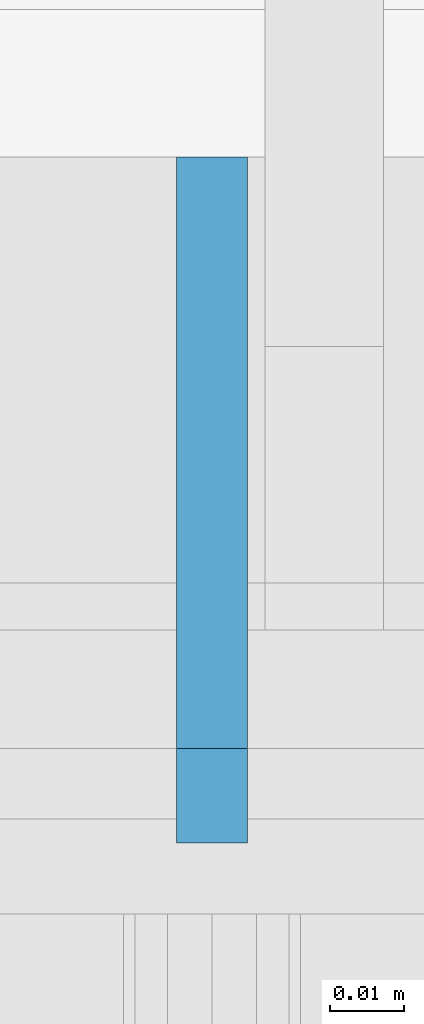
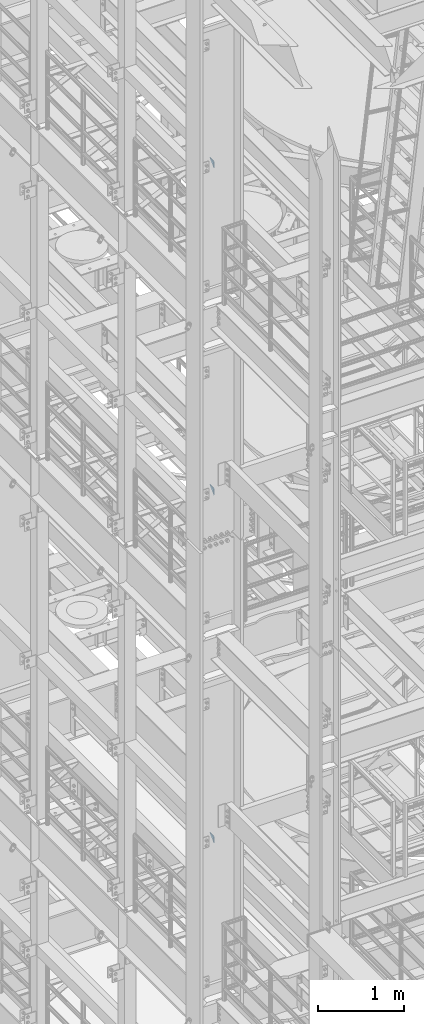
# One storey, part 1461 of 1876: 3 plates, 2 elements without a shape of their own.
"""IFC2X3 building model written with IfcOpenShell, lengths in millimetres."""

from ifc_helpers import new_model, si_unit, frame, origin_with_axes, place, context, subcontext, project, spatial, faceted_brep, material, type_object, element, aggregate, save


model = new_model("IFC2X3")

# Units and contexts
model_context = context("Model", 3, precision=1e-05, world=origin_with_axes())
body_context = subcontext(model_context, "Body", "Model", "MODEL_VIEW")
ifc_project = project(units=[si_unit("LENGTHUNIT", "METRE", prefix="MILLI"), si_unit("AREAUNIT", "SQUARE_METRE"), si_unit("VOLUMEUNIT", "CUBIC_METRE"), si_unit("MASSUNIT", "GRAM", prefix="KILO"), si_unit("TIMEUNIT", "SECOND"), si_unit("PLANEANGLEUNIT", "RADIAN"), si_unit("SOLIDANGLEUNIT", "STERADIAN"), si_unit("THERMODYNAMICTEMPERATUREUNIT", "DEGREE_CELSIUS"), si_unit("LUMINOUSINTENSITYUNIT", "LUMEN")], contexts=[model_context])

# Site, building, storey
site_placement = place(None, origin_with_axes())
site = spatial("IfcSite", under=ifc_project, at=site_placement, CompositionType="ELEMENT")
building_placement = place(site_placement, origin_with_axes())
building = spatial("IfcBuilding", under=site, at=building_placement, Name="Undefined", CompositionType="ELEMENT")
storey_placement = place(building_placement, origin_with_axes())
storey = spatial("IfcBuildingStorey", under=building, at=storey_placement, Name="Undefined", CompositionType="ELEMENT", Elevation=0.0)

# Assembly, plates
assembly_1_placement = place(storey_placement, origin_with_axes())
assembly_1 = element("IfcElementAssembly", 1, at=assembly_1_placement, inside=storey, Name="COLUMN", AssemblyPlace="NOTDEFINED", PredefinedType="RIGID_FRAME")
ifc_material = material(Name="STEEL/A36")
plate_type = type_object("IfcPlateType", PredefinedType="NOTDEFINED")
plate_1_placement = place(assembly_1_placement, frame((0.0, -4458.49374940317, 19862.8), z_axis=(0.0, -0.707106781186548, 0.707106781186548), x_axis=(0.0, -0.707106781186548, -0.707106781186548)))
plate_1 = element("IfcPlate", 2, at=plate_1_placement, type_object=plate_type, material=ifc_material, Name="PLATE", context=body_context, shape_type="Brep", body=[
    faceted_brep([(0.0, -4.76249999999982, 0.0), (56.1266013136901, -4.76249999997708, 56.1266013135391), (56.1266013136883, 4.76250000002256, 56.1266013135428), (0.0, 4.76249999999982, 0.0), (74.0871132860975, -4.7624999999698, 56.1266013135246), (74.0871132860993, 4.76250000002983, 56.1266013135282), (130.213714599717, -4.76249999994707, -1.30967237055302e-10), (130.213714599715, 4.76250000005257, -1.23691279441118e-10)], [[[0, 1, 2, 3]], [[1, 4, 5, 2]], [[4, 6, 7, 5]], [[6, 0, 3, 7]], [[5, 7, 3, 2]], [[6, 4, 1, 0]]]),
])
plate_2_placement = place(assembly_1_placement, frame((0.0, -4458.49374940317, 15240.0), z_axis=(0.0, -0.707106781186548, 0.707106781186548), x_axis=(0.0, -0.707106781186548, -0.707106781186548)))
plate_2 = element("IfcPlate", 3, at=plate_2_placement, type_object=plate_type, material=ifc_material, Name="PLATE", context=body_context, shape_type="Brep", body=[
    faceted_brep([(0.0, -4.76249999999982, 0.0), (56.1266013136901, -4.76249999997708, 56.1266013135391), (56.1266013136883, 4.76250000002256, 56.1266013135428), (0.0, 4.76249999999982, 0.0), (74.0871132860975, -4.7624999999698, 56.1266013135246), (74.0871132860993, 4.76250000002983, 56.1266013135282), (130.213714599717, -4.76249999994707, -1.30967237055302e-10), (130.213714599715, 4.76250000005257, -1.23691279441118e-10)], [[[0, 1, 2, 3]], [[1, 4, 5, 2]], [[4, 6, 7, 5]], [[6, 0, 3, 7]], [[5, 7, 3, 2]], [[6, 4, 1, 0]]]),
])
aggregate(assembly_1, [plate_1, plate_2])

# Assembly, plate
assembly_2_placement = place(storey_placement, origin_with_axes())
assembly_2 = element("IfcElementAssembly", 4, at=assembly_2_placement, inside=storey, Name="COLUMN", AssemblyPlace="NOTDEFINED", PredefinedType="RIGID_FRAME")
plate_3_placement = place(assembly_2_placement, frame((0.0, -4458.49374940317, 10325.1), z_axis=(0.0, -0.707106781186548, 0.707106781186548), x_axis=(0.0, -0.707106781186548, -0.707106781186548)))
plate_3 = element("IfcPlate", 5, at=plate_3_placement, type_object=plate_type, material=ifc_material, Name="PLATE", context=body_context, shape_type="Brep", body=[
    faceted_brep([(0.0, -4.76249999999982, 0.0), (56.1266013136901, -4.76249999997708, 56.1266013135391), (56.1266013136883, 4.76250000002256, 56.1266013135428), (0.0, 4.76249999999982, 0.0), (74.0871132860975, -4.7624999999698, 56.1266013135246), (74.0871132860993, 4.76250000002983, 56.1266013135282), (130.213714599717, -4.76249999994707, -1.30967237055302e-10), (130.213714599715, 4.76250000005257, -1.23691279441118e-10)], [[[0, 1, 2, 3]], [[1, 4, 5, 2]], [[4, 6, 7, 5]], [[6, 0, 3, 7]], [[5, 7, 3, 2]], [[6, 4, 1, 0]]]),
])
aggregate(assembly_2, [plate_3])

save(model, "model.ifc")
